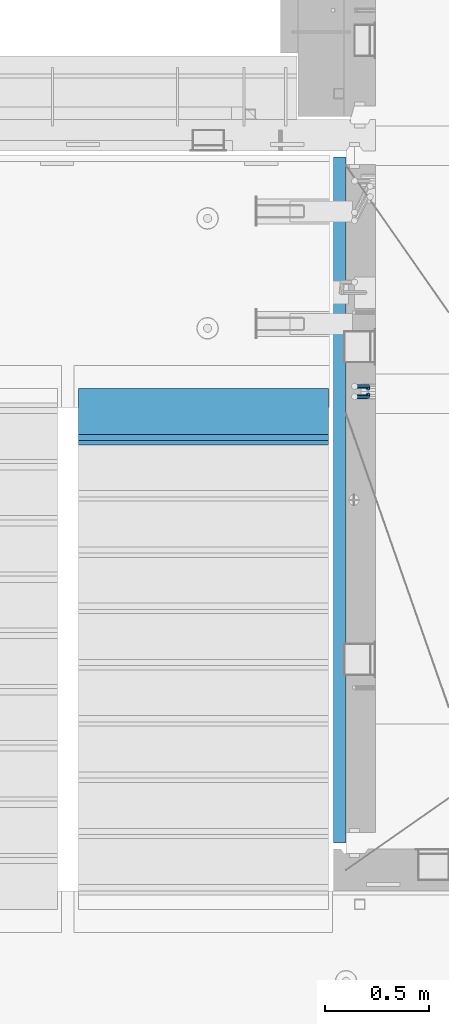
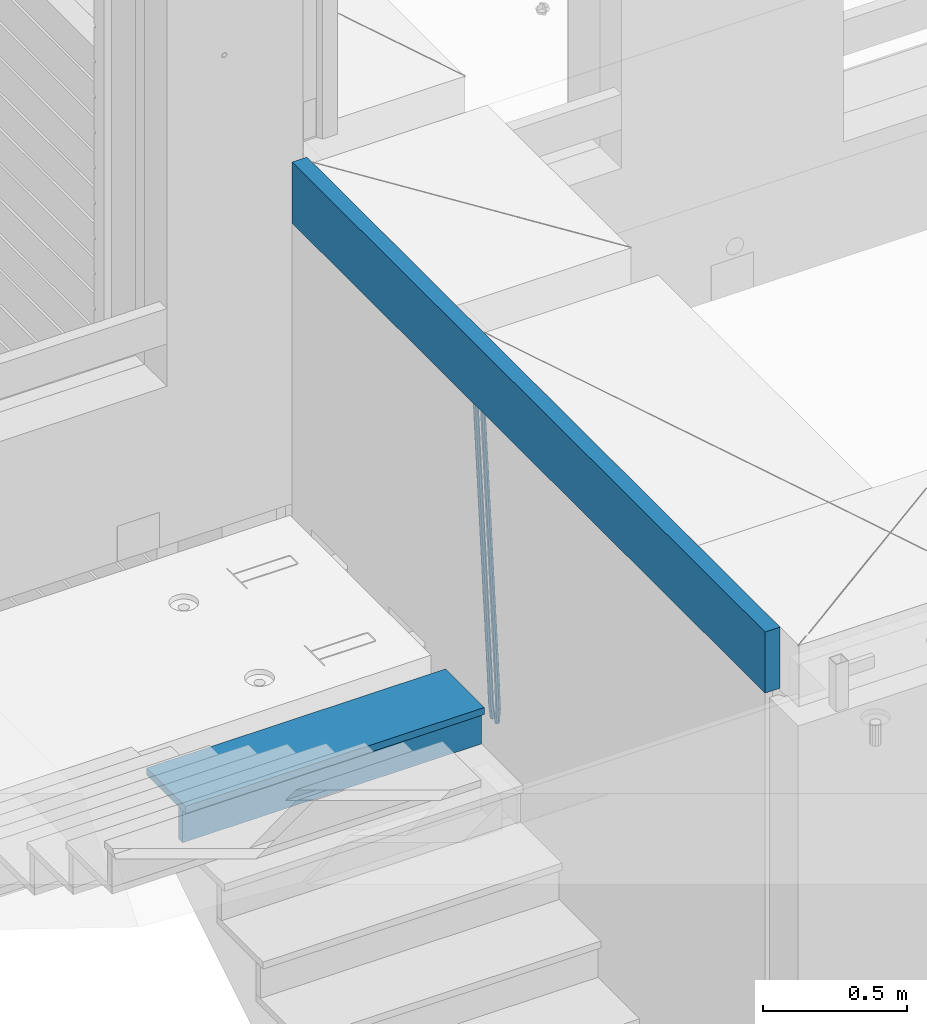
# One storey, part 120 of 350: 5 beams, 2 elements without a shape of their own.
"""IFC2X3 building model written with IfcOpenShell, lengths in millimetres."""

from ifc_helpers import new_model, si_unit, frame, origin_with_axes, place, context, subcontext, project, spatial, faceted_brep, material, type_object, element, aggregate, save


model = new_model("IFC2X3")

# Units and contexts
model_context = context("Model", 3, precision=1e-05, world=origin_with_axes())
body_context = subcontext(model_context, "Body", "Model", "MODEL_VIEW")
ifc_project = project(units=[si_unit("LENGTHUNIT", "METRE", prefix="MILLI"), si_unit("AREAUNIT", "SQUARE_METRE"), si_unit("VOLUMEUNIT", "CUBIC_METRE"), si_unit("MASSUNIT", "GRAM", prefix="KILO"), si_unit("TIMEUNIT", "SECOND"), si_unit("PLANEANGLEUNIT", "RADIAN"), si_unit("SOLIDANGLEUNIT", "STERADIAN"), si_unit("THERMODYNAMICTEMPERATUREUNIT", "DEGREE_CELSIUS"), si_unit("LUMINOUSINTENSITYUNIT", "LUMEN")], contexts=[model_context])

# Site, building, storey
site_placement = place(None, origin_with_axes())
site = spatial("IfcSite", under=ifc_project, at=site_placement, CompositionType="ELEMENT")
building_placement = place(site_placement, origin_with_axes())
building = spatial("IfcBuilding", under=site, at=building_placement, CompositionType="ELEMENT")
storey_placement = place(building_placement, origin_with_axes())
storey = spatial("IfcBuildingStorey", under=building, at=storey_placement, Name="2", CompositionType="ELEMENT", Elevation=0.0)

# Assembly, beams
assembly_1_placement = place(storey_placement, origin_with_axes())
assembly_1 = element("IfcElementAssembly", 1, at=assembly_1_placement, inside=storey, AssemblyPlace="NOTDEFINED", PredefinedType="REINFORCEMENT_UNIT")
ifc_material_1 = material()
beam_type_1 = type_object("IfcBeamType", Name="D20", PredefinedType="NOTDEFINED")
beam_1_placement = place(assembly_1_placement, frame((22375.0000022791, 19290.4700000039, 85985.0), z_axis=(-0.15890508605452, 0.973589036334047, -0.163931577056242), x_axis=(-0.0263727870048703, 0.161796289029781, 0.986471711181718)))
beam_1 = element("IfcBeam", 2, at=beam_1_placement, type_object=beam_type_1, material=ifc_material_1, Name="JM20", ObjectType="D20", context=body_context, shape_type="Brep", body=[
    faceted_brep([(0.0, -10.0, 0.0), (-4.19531716033816e-08, -7.07106781186667, -7.07106781187031), (60.5120847452927, -7.07106784077769, -7.0710678127632), (60.5120847456128, -10.000000028911, -8.96534402272664e-10), (0.0, 0.0, -10.0), (60.5120847479557, -2.89146555587649e-08, -10.0000000008984), (4.196772351861e-08, 7.07106781186303, -7.07106781186667), (60.5120847520593, 7.07106778294838, -7.0710678127632), (0.0, 10.0, 0.0), (60.5120847551734, 9.99999997108898, -8.94715412869118e-10), (4.196772351861e-08, 7.07106781185939, 7.07106781185939), (60.512084755479, 7.07106778295201, 7.07106781097195), (0.0, 0.0, 10.0), (60.512084752816, -2.89110175799578e-08, 9.9999999991071), (-4.19531716033816e-08, -7.07106781187031, 7.07106781185939), (60.5120847487415, -7.07106784077769, 7.07106781096832), (61.1107048256381, -7.07106784106145, -7.07106781277048), (61.616696962592, -10.0000000294385, -9.12905306904577e-10), (61.0120847479702, -2.91511241812259e-08, -10.0000000009038), (61.3786070335627, 7.07106778254092, -7.0710678127723), (61.9955678984406, 9.99999997037958, -9.2018126451876e-10), (62.5015600354091, 7.07106778200614, 7.07106781093921), (62.6001801130624, -2.9907823773101e-08, 9.99999999907436), (62.2336578274699, -7.07106784159623, 7.07106781094103), (61.7013993430301, -7.09359767751084, -7.16550506250837), (62.7066844218498, -10.0415735305724, -0.174261679103211), (61.505464887392, -0.0188181720659486, -10.0788791204338), (62.2336568017054, 7.03845510227256, -7.207768842012), (63.4594101385883, 9.94416717476997, -0.234031689273024), (64.464695217408, 6.99619132171574, 6.75721169413032), (64.6606296730461, -0.0785881837327906, 9.67058575205397), (63.9324377587182, -7.1358614580713, 6.79947547363395), (179.287252569251, -11.5784709304826, -25.9645361348155), (180.292537648071, -14.5264467835441, -18.973292751414), (179.091318113613, -4.50369142503769, -28.877910192741), (179.819510027926, 2.55358184929719, -26.0067999143191), (181.045263364809, 5.45929392180187, -19.033062761582), (182.050548443614, 2.511318068744, -12.0418193781786), (182.246482899252, -4.56346143670453, -9.12844532025679), (181.518290984939, -11.6207347110394, -11.9995555986786), (179.796944029818, -11.5979112078276, -26.0460230258138), (180.785917787493, -14.5452649264626, -19.0521718709458), (179.631039013402, -4.52427706319941, -28.9641980384947), (180.385387646791, 2.53199856077117, -26.0972695639282), (181.618102731314, 5.43744510340548, -19.1246454201662), (182.607076488988, 2.49009138477413, -12.1307942652963), (182.772981505375, -4.58354275985403, -9.21261925261729), (182.018632872001, -11.6398183838246, -12.0795477271802), (180.306575384253, -11.6215474691344, -26.1267734773298), (181.279244090445, -14.5681079330752, -19.1303214631914), (180.170689328603, -4.54931932109321, -29.0497458967745), (180.951186131948, 2.5057611781267, -26.1870011206463), (182.190861352254, 5.41092355571527, -19.2154962132006), (183.16353005846, 2.46436309177807, -12.2190441990567), (183.299416114096, -4.60786505625947, -9.29607177961748), (182.518919310765, -11.662945555483, -12.1588165557403), (300.637581828458, -17.193417372393, -45.2021641841727), (301.610250534635, -20.1399778363302, -38.2057121700307), (300.501695772793, -10.1211892243555, -48.125136603612), (301.282192576138, -3.06610872513556, -45.2623918274874), (302.521867796473, -0.160946347543359, -38.2908869200398), (303.494536502651, -3.10750681148056, -31.2944349058978), (303.630422558286, -10.1797349595217, -28.3714624864531), (302.849925754956, -17.2348154587417, -31.2342072625831), (301.135146648914, -17.2164568742628, -45.2810403078945), (302.103568397841, -20.1628206848691, -38.2839150477537), (301.007079483054, -10.1445907761881, -48.2052522115043), (301.794386909154, -3.08982563961035, -45.3435870847131), (303.035874914756, -0.184747202180006, -38.3723695478091), (304.004296663683, -3.13111101278264, -31.3752442876664), (304.132363829543, -10.2029771108573, -28.4510323840584), (303.345056403443, -17.2577422474315, -31.3126975108532), (301.632689949649, -17.2405558216851, -45.3597353949606), (302.596865217929, -20.1867113775443, -38.3619373656909), (301.512440876206, -10.1690694440185, -48.2851865283189), (302.306558273951, -3.11463305844518, -45.424601167904), (303.549858941391, -0.209639824737678, -38.4536714215171), (304.514034209686, -3.15579538060047, -31.4558733922438), (304.634283283129, -10.2272817582634, -28.5304222588836), (303.840165885384, -17.2817181438368, -31.3910076193022), (1282.62444446853, -64.7506719518351, -200.525713980774), (1283.58861973681, -67.6968275076943, -193.527915951503), (1282.50419539507, -57.6791855741649, -203.451165114133), (1283.29831279283, -50.6247491885915, -200.590579753716), (1284.54161346027, -47.7197559548877, -193.619650007329), (1285.50578872855, -50.6659115107432, -186.621851978058), (1285.62603780199, -57.7373978884098, -183.696400844703), (1284.83192040426, -64.7918342739831, -186.556986205121), (1283.16036625447, -64.7766270183929, -200.610482102403), (1284.18303170854, -67.7256152948248, -193.621935615638), (1282.99823367732, -57.703112193376, -203.529308414698), (1283.79160904189, -50.6486398706256, -200.668605684988), (1285.07574381966, -47.7456242614098, -193.704134774427), (1286.09840927372, -50.6946125378345, -186.715588287659), (1286.26054185088, -57.7681273628514, -183.796761975365), (1285.4671664863, -64.8225996856127, -186.657464705073), (1283.69517474226, -64.7992414390355, -200.702893843656), (1284.77620887742, -67.7506978399178, -193.72443311951), (1283.49124566819, -57.7239592457336, -203.61449796867), (1284.28388054106, -50.6694556112197, -200.753667286384), (1285.60876460234, -47.7681630887928, -193.796237610821), (1286.68979873748, -50.7196194896715, -186.817776886675), (1286.89372781155, -57.7949016829771, -183.906172761662), (1286.10109293868, -64.8494053174909, -186.767003443949), (1305.19726392522, -65.7084590385093, -204.418327587487), (1306.27829806038, -68.6599154393916, -197.43986686334), (1304.99333485115, -58.6331768452073, -207.3299317125), (1305.78596972401, -51.5786732107008, -204.469101030216), (1307.11085378527, -48.6773806882629, -197.511671354648), (1308.19188792045, -51.6288370891452, -190.533210630503), (1308.39581699451, -58.7041192824508, -187.62160650549), (1307.60318212165, -65.758622916961, -190.482437187782), (1305.83218118416, -65.7353065667266, -204.528037531872), (1306.8626665273, -68.6846255078017, -197.540842275655), (1305.64065308902, -58.6605487498273, -207.441784472648), (1306.40027680244, -51.6046492357418, -204.575249657393), (1307.66607505539, -48.7008582650778, -197.607610303868), (1308.69656039854, -51.6501772061529, -190.620415047653), (1308.88808849367, -58.7249350230522, -187.706668106881), (1308.12846478027, -65.7808345371377, -190.573202922138), (1306.46882402551, -65.7602792894941, -204.627733284394), (1307.44862319478, -68.7076100329687, -197.632600773693), (1306.28973061276, -58.6860092309689, -207.543427447275), (1307.01625344875, -51.6288113137889, -204.671709165457), (1308.2228053096, -48.7226963654903, -197.694792061111), (1309.20260447887, -51.6700271089649, -190.699659550409), (1309.38169789161, -58.74429716749, -187.783965387529), (1308.65517505561, -65.80149508467, -190.655683669345), (1405.22131312029, -69.6339088545756, -220.091982741469), (1406.20111228956, -72.5812395980538, -213.096850230768), (1405.04221970754, -62.5596387960541, -223.007676904353), (1405.76874254357, -55.5024408788704, -220.135958622533), (1406.97529440439, -52.5963259305718, -213.159041518189), (1407.95509357366, -55.54365667405, -206.163909007488), (1408.13418698641, -62.6179267325751, -203.248214844601), (1407.40766415041, -69.6751246497552, -206.119933126425)], [[[0, 1, 2, 3]], [[1, 4, 5, 2]], [[4, 6, 7, 5]], [[6, 8, 9, 7]], [[8, 10, 11, 9]], [[10, 12, 13, 11]], [[12, 14, 15, 13]], [[14, 0, 3, 15]], [[14, 12, 10, 8, 6, 4, 1, 0]], [[3, 2, 16, 17]], [[2, 5, 18, 16]], [[5, 7, 19, 18]], [[7, 9, 20, 19]], [[9, 11, 21, 20]], [[11, 13, 22, 21]], [[13, 15, 23, 22]], [[15, 3, 17, 23]], [[17, 16, 24, 25]], [[16, 18, 26, 24]], [[18, 19, 27, 26]], [[19, 20, 28, 27]], [[20, 21, 29, 28]], [[21, 22, 30, 29]], [[22, 23, 31, 30]], [[23, 17, 25, 31]], [[25, 24, 32, 33]], [[24, 26, 34, 32]], [[26, 27, 35, 34]], [[27, 28, 36, 35]], [[28, 29, 37, 36]], [[29, 30, 38, 37]], [[30, 31, 39, 38]], [[31, 25, 33, 39]], [[33, 32, 40, 41]], [[32, 34, 42, 40]], [[34, 35, 43, 42]], [[35, 36, 44, 43]], [[36, 37, 45, 44]], [[37, 38, 46, 45]], [[38, 39, 47, 46]], [[39, 33, 41, 47]], [[41, 40, 48, 49]], [[40, 42, 50, 48]], [[42, 43, 51, 50]], [[43, 44, 52, 51]], [[44, 45, 53, 52]], [[45, 46, 54, 53]], [[46, 47, 55, 54]], [[47, 41, 49, 55]], [[49, 48, 56, 57]], [[48, 50, 58, 56]], [[50, 51, 59, 58]], [[51, 52, 60, 59]], [[52, 53, 61, 60]], [[53, 54, 62, 61]], [[54, 55, 63, 62]], [[55, 49, 57, 63]], [[57, 56, 64, 65]], [[56, 58, 66, 64]], [[58, 59, 67, 66]], [[59, 60, 68, 67]], [[60, 61, 69, 68]], [[61, 62, 70, 69]], [[62, 63, 71, 70]], [[63, 57, 65, 71]], [[65, 64, 72, 73]], [[64, 66, 74, 72]], [[66, 67, 75, 74]], [[67, 68, 76, 75]], [[68, 69, 77, 76]], [[69, 70, 78, 77]], [[70, 71, 79, 78]], [[71, 65, 73, 79]], [[73, 72, 80, 81]], [[72, 74, 82, 80]], [[74, 75, 83, 82]], [[75, 76, 84, 83]], [[76, 77, 85, 84]], [[77, 78, 86, 85]], [[78, 79, 87, 86]], [[79, 73, 81, 87]], [[81, 80, 88, 89]], [[80, 82, 90, 88]], [[82, 83, 91, 90]], [[83, 84, 92, 91]], [[84, 85, 93, 92]], [[85, 86, 94, 93]], [[86, 87, 95, 94]], [[87, 81, 89, 95]], [[89, 88, 96, 97]], [[88, 90, 98, 96]], [[90, 91, 99, 98]], [[91, 92, 100, 99]], [[92, 93, 101, 100]], [[93, 94, 102, 101]], [[94, 95, 103, 102]], [[95, 89, 97, 103]], [[97, 96, 104, 105]], [[96, 98, 106, 104]], [[98, 99, 107, 106]], [[99, 100, 108, 107]], [[100, 101, 109, 108]], [[101, 102, 110, 109]], [[102, 103, 111, 110]], [[103, 97, 105, 111]], [[105, 104, 112, 113]], [[104, 106, 114, 112]], [[106, 107, 115, 114]], [[107, 108, 116, 115]], [[108, 109, 117, 116]], [[109, 110, 118, 117]], [[110, 111, 119, 118]], [[111, 105, 113, 119]], [[113, 112, 120, 121]], [[112, 114, 122, 120]], [[114, 115, 123, 122]], [[115, 116, 124, 123]], [[116, 117, 125, 124]], [[117, 118, 126, 125]], [[118, 119, 127, 126]], [[119, 113, 121, 127]], [[121, 120, 128, 129]], [[120, 122, 130, 128]], [[122, 123, 131, 130]], [[123, 124, 132, 131]], [[124, 125, 133, 132]], [[125, 126, 134, 133]], [[126, 127, 135, 134]], [[127, 121, 129, 135]], [[130, 131, 132, 133, 134, 135, 129, 128]]]),
])
beam_2_placement = place(assembly_1_placement, frame((22375.0000022791, 19260.4700000039, 85985.0), z_axis=(-0.158495816053634, -0.973655762329485, -0.163931488055477), x_axis=(-0.0263727879979646, -0.161796198987477, 0.986471725923465)))
beam_2 = element("IfcBeam", 3, at=beam_2_placement, type_object=beam_type_1, material=ifc_material_1, Name="JM20", ObjectType="D20", context=body_context, shape_type="Brep", body=[
    faceted_brep([(0.0, -10.0, 0.0), (-4.19531716033816e-08, -7.07106781186667, -7.07106781187031), (60.5120052037528, -7.07106781749098, -7.07106782543269), (60.5120052045822, -10.0000000056316, -1.35623849928379e-08), (0.0, 0.0, -10.0), (60.512005203942, -5.62431523576379e-09, -10.0000000135624), (4.196772351861e-08, 7.07106781186303, -7.07106781186667), (60.5120052050625, 7.07106780623872, -7.07106782543269), (0.0, 10.0, 0.0), (60.5120052064449, 9.99999999437205, -1.35623849928379e-08), (4.196772351861e-08, 7.07106781185939, 7.07106781185939), (60.5120052072889, 7.07106780623872, 7.07106779830065), (0.0, 0.0, 10.0), (60.5120052070852, -5.62795321457088e-09, 9.99999998643762), (-4.19531716033816e-08, -7.07106781187031, 7.07106781185939), (60.5120052059501, -7.07106781749098, 7.07106779830065), (61.3783176868601, -7.07106781757102, -7.07106782562914), (61.9952377020818, -10.0000000057662, -1.38970790430903e-08), (61.0120052039565, -5.67160896025598e-09, -10.0000000136788), (61.1108811377926, 7.07106780618051, -7.07106782556366), (61.6170253073215, 9.99999999427382, -1.38097675517201e-08), (62.2339453225432, 7.07106780607864, 7.07106779791502), (62.6002578054613, -5.81712811253965e-09, 9.99999998597195), (62.5013818716106, -7.07106781767652, 7.07106779785681), (62.2331604305218, -7.03851970548931, -7.2077492888784), (63.4588326085068, -9.94427367315438, -0.23401532828575), (61.5053853412101, 0.0187854284049536, -10.0788869429962), (61.7018281175842, 7.09356809489327, -7.16555479231465), (62.7074152454443, 10.041516558791, -0.174343299004249), (63.9330874234438, 7.13576259111869, 6.79939066157385), (64.6608625127556, 0.078457457228069, 9.6705283156989), (64.4644197363668, -6.99632520926025, 6.75719616502465), (179.818932802998, -2.5614449136192, -26.0086288006423), (181.044604980983, -5.46719888128791, -19.034894840057), (179.091157713687, 4.49586022027506, -28.8797664547601), (179.287600490061, 11.5706428867597, -25.9664343040859), (180.293187617921, 14.5185913506575, -18.9752228107754), (181.51885979592, 11.6128373829924, -12.0014888501901), (182.246634885232, 4.55553224909454, -9.13035119606502), (182.050192108843, -2.51925041739014, -12.0436833467465), (180.384803383684, -2.53989940806059, -26.0991062826724), (181.617449868121, -5.44538782921518, -19.126487449299), (179.630864755702, 4.51640954987306, -28.9660606284815), (179.797281007268, 11.5900489573214, -26.0479275136822), (180.786567755189, 14.5373767847341, -19.0541097400928), (182.019214239626, 11.6318883635759, -12.0814909067267), (182.773152867594, 4.5755794056422, -9.21453656090307), (182.606736616028, -2.49806000179888, -12.1326696757169), (180.950594849404, -2.51369963445904, -26.1888475202795), (182.190214025846, -5.41890367426822, -19.2173500092686), (180.170501221772, 4.54141556354443, -29.051616675737), (180.306901410135, 11.613651120846, -26.1286861303379), (181.279894034014, 14.5601873642845, -19.132268955691), (182.519513210456, 11.6549833244717, -12.16077144468), (183.299606838089, 4.59986812646821, -9.29800228921522), (183.163206649726, -2.4723674308334, -12.2209328346216), (301.281596738394, 3.05026059481679, -45.2665532172323), (302.521215914836, 0.145056555003976, -38.2950557062213), (300.501503110776, 10.1053757928166, -48.1293223726971), (300.637903299124, 17.1776113501182, -45.2063918272906), (301.610895923019, 20.1241475935603, -38.2099746526364), (302.850515099461, 17.2189435537439, -31.2384771416328), (303.630608727079, 10.163828355744, -28.375707986168), (303.494208538745, 3.09159279844243, -31.2986385315744), (301.793789297284, 3.07394376027514, -45.3477580501058), (303.035224417355, 0.168823687501572, -38.3765484452742), (301.006883331909, 10.128743964, -48.2094471532764), (301.135465363477, 17.2006180191747, -45.285277089446), (302.104213781728, 20.14695801567, -38.2881870233177), (303.345648901799, 17.2418379429, -31.3169774184789), (304.132554867159, 10.1870377391679, -28.455288315301), (304.003972835591, 3.11516368399316, -31.3794583791459), (302.305958891287, 3.09871749445665, -45.4287821432372), (303.549209831341, 0.193682665365486, -38.4578608624288), (301.512241238641, 10.1531893083702, -48.2893910778876), (301.633005909636, 17.2246841938904, -45.3639817491057), (302.597510597858, 20.1708163533331, -38.3662192661868), (303.840761537926, 17.2657815242455, -31.3952979853784), (304.634479190572, 10.211309710332, -28.5346890507208), (304.513714519577, 3.13981482481177, -31.4600983795099), (1283.29235311947, 50.544232039254, -200.613633821762), (1284.53560405952, 47.6391972101628, -193.642712540946), (1282.49863546679, 57.5987038531639, -203.474242756405), (1282.6194001378, 64.6701987386878, -200.548833427623), (1283.58390482602, 67.6163308981268, -193.551070944704), (1284.82715576609, 64.7112960690356, -186.580149663889), (1285.62087341874, 57.6568242551293, -183.719540729246), (1285.50010874774, 50.5853293696091, -186.644950058035), (1283.86584870378, 50.5719692160856, -200.704356616399), (1285.05399320807, 47.6642691581874, -193.72471790167), (1283.12497041782, 57.628996611762, -203.573324351266), (1283.26535480202, 64.701440406865, -200.651018717188), (1284.20476658808, 67.6463589453451, -193.649286721222), (1285.39291109238, 64.7386588874433, -186.6696480065), (1286.13378937833, 57.6816314917669, -183.800680271634), (1285.99340499415, 50.6091876966675, -186.722985905704), (1284.44060590031, 50.5936921758439, -200.788496023008), (1285.57352274218, 47.68390478734, -193.800772463459), (1283.75268322045, 57.6527210297136, -203.665215993606), (1283.91273047855, 64.7259079835276, -200.745788831606), (1284.82699416149, 67.6698760489453, -193.740375374167), (1285.95991100336, 64.7600886604341, -186.752651814619), (1286.64783368325, 57.7010598065717, -183.875931844028), (1286.48778642512, 50.6278728527504, -186.795359006021), (1306.02894027183, 51.4096237058839, -203.948838607132), (1307.16185711371, 48.4998363173727, -196.961115047583), (1305.34101759194, 58.4686525597535, -206.825558577722), (1305.50106485008, 65.5418395135639, -203.90613141573), (1306.415328533, 68.4858075789816, -196.900717958291), (1307.54824537487, 65.5760201904777, -189.912994398743), (1308.23616805475, 58.5169913366044, -187.036274428152), (1308.07612079663, 51.4438043827904, -189.955701590145), (1306.55429855913, 51.4294796328759, -204.025746447209), (1307.74597489809, 48.5219130607366, -197.046624762064), (1305.83539902292, 58.4873377158401, -206.897931678046), (1306.0103978878, 65.5610897659317, -203.980693299985), (1306.97678319212, 68.507027769072, -196.982909990227), (1308.16845953107, 65.5994611969327, -190.00378830509), (1308.88735906727, 58.5416031139684, -187.131603074253), (1308.71236020241, 51.4678510638769, -190.048841452306), (1307.07832423707, 51.4505295560484, -204.110977857723), (1308.32861102538, 48.5453173445967, -197.141389009383), (1306.32852641959, 58.507146466156, -206.978137563652), (1306.51843896537, 65.5814975934481, -204.063324856921), (1307.5368136808, 68.5295239925508, -197.073997489359), (1308.78710046913, 65.6243117811064, -190.104408641026), (1309.53689828661, 58.5676948709952, -187.237248935096), (1309.34698574082, 51.4933437436994, -190.152061641827), (1405.73383542724, 55.413485988287, -220.157039583137), (1406.98412221558, 52.5082737768425, -213.187450734797), (1404.98403760976, 62.4701028983982, -223.024199289066), (1405.17395015556, 69.544454025694, -220.109386582335), (1406.19232487098, 72.492480424793, -213.12005921478), (1407.44261165931, 69.5872682133449, -206.15047036644), (1408.1924094768, 62.5306513032374, -203.28331066051), (1408.00249693099, 55.4563001759452, -206.198123367241)], [[[0, 1, 2, 3]], [[1, 4, 5, 2]], [[4, 6, 7, 5]], [[6, 8, 9, 7]], [[8, 10, 11, 9]], [[10, 12, 13, 11]], [[12, 14, 15, 13]], [[14, 0, 3, 15]], [[14, 12, 10, 8, 6, 4, 1, 0]], [[3, 2, 16, 17]], [[2, 5, 18, 16]], [[5, 7, 19, 18]], [[7, 9, 20, 19]], [[9, 11, 21, 20]], [[11, 13, 22, 21]], [[13, 15, 23, 22]], [[15, 3, 17, 23]], [[17, 16, 24, 25]], [[16, 18, 26, 24]], [[18, 19, 27, 26]], [[19, 20, 28, 27]], [[20, 21, 29, 28]], [[21, 22, 30, 29]], [[22, 23, 31, 30]], [[23, 17, 25, 31]], [[25, 24, 32, 33]], [[24, 26, 34, 32]], [[26, 27, 35, 34]], [[27, 28, 36, 35]], [[28, 29, 37, 36]], [[29, 30, 38, 37]], [[30, 31, 39, 38]], [[31, 25, 33, 39]], [[33, 32, 40, 41]], [[32, 34, 42, 40]], [[34, 35, 43, 42]], [[35, 36, 44, 43]], [[36, 37, 45, 44]], [[37, 38, 46, 45]], [[38, 39, 47, 46]], [[39, 33, 41, 47]], [[41, 40, 48, 49]], [[40, 42, 50, 48]], [[42, 43, 51, 50]], [[43, 44, 52, 51]], [[44, 45, 53, 52]], [[45, 46, 54, 53]], [[46, 47, 55, 54]], [[47, 41, 49, 55]], [[49, 48, 56, 57]], [[48, 50, 58, 56]], [[50, 51, 59, 58]], [[51, 52, 60, 59]], [[52, 53, 61, 60]], [[53, 54, 62, 61]], [[54, 55, 63, 62]], [[55, 49, 57, 63]], [[57, 56, 64, 65]], [[56, 58, 66, 64]], [[58, 59, 67, 66]], [[59, 60, 68, 67]], [[60, 61, 69, 68]], [[61, 62, 70, 69]], [[62, 63, 71, 70]], [[63, 57, 65, 71]], [[65, 64, 72, 73]], [[64, 66, 74, 72]], [[66, 67, 75, 74]], [[67, 68, 76, 75]], [[68, 69, 77, 76]], [[69, 70, 78, 77]], [[70, 71, 79, 78]], [[71, 65, 73, 79]], [[73, 72, 80, 81]], [[72, 74, 82, 80]], [[74, 75, 83, 82]], [[75, 76, 84, 83]], [[76, 77, 85, 84]], [[77, 78, 86, 85]], [[78, 79, 87, 86]], [[79, 73, 81, 87]], [[81, 80, 88, 89]], [[80, 82, 90, 88]], [[82, 83, 91, 90]], [[83, 84, 92, 91]], [[84, 85, 93, 92]], [[85, 86, 94, 93]], [[86, 87, 95, 94]], [[87, 81, 89, 95]], [[89, 88, 96, 97]], [[88, 90, 98, 96]], [[90, 91, 99, 98]], [[91, 92, 100, 99]], [[92, 93, 101, 100]], [[93, 94, 102, 101]], [[94, 95, 103, 102]], [[95, 89, 97, 103]], [[97, 96, 104, 105]], [[96, 98, 106, 104]], [[98, 99, 107, 106]], [[99, 100, 108, 107]], [[100, 101, 109, 108]], [[101, 102, 110, 109]], [[102, 103, 111, 110]], [[103, 97, 105, 111]], [[105, 104, 112, 113]], [[104, 106, 114, 112]], [[106, 107, 115, 114]], [[107, 108, 116, 115]], [[108, 109, 117, 116]], [[109, 110, 118, 117]], [[110, 111, 119, 118]], [[111, 105, 113, 119]], [[113, 112, 120, 121]], [[112, 114, 122, 120]], [[114, 115, 123, 122]], [[115, 116, 124, 123]], [[116, 117, 125, 124]], [[117, 118, 126, 125]], [[118, 119, 127, 126]], [[119, 113, 121, 127]], [[121, 120, 128, 129]], [[120, 122, 130, 128]], [[122, 123, 131, 130]], [[123, 124, 132, 131]], [[124, 125, 133, 132]], [[125, 126, 134, 133]], [[126, 127, 135, 134]], [[127, 121, 129, 135]], [[130, 131, 132, 133, 134, 135, 129, 128]]]),
])
ifc_material_2 = material(Name="CONCRETE/C25/30")
beam_type_2 = type_object("IfcBeamType", Name="260X60", PredefinedType="NOTDEFINED")
beam_3_placement = place(assembly_1_placement, frame((22240.0000000001, 20400.0, 87600.0), z_axis=(0.0, 0.0, 1.0), x_axis=(0.0, -1.0, 0.0)))
beam_3 = element("IfcBeam", 4, at=beam_3_placement, type_object=beam_type_2, material=ifc_material_2, ObjectType="260X60", context=body_context, shape_type="Brep", body=[
    faceted_brep([(0.0, 30.0, -130.0), (0.0, 30.0, 130.0), (3290.0, 30.0, 130.0), (3290.0, 30.0, -130.0), (0.0, -30.0, 130.0), (3290.0, -30.0, 130.0), (0.0, -30.0, -130.0), (3290.0, -30.0, -130.0)], [[[0, 1, 2, 3]], [[1, 4, 5, 2]], [[4, 6, 7, 5]], [[6, 0, 3, 7]], [[5, 7, 3, 2]], [[6, 4, 1, 0]]]),
])
aggregate(assembly_1, [beam_1, beam_2, beam_3])

assembly_2_placement = place(storey_placement, origin_with_axes())
assembly_2 = element("IfcElementAssembly", 5, at=assembly_2_placement, inside=storey, Name="E9", AssemblyPlace="NOTDEFINED", PredefinedType="NOTDEFINED")
ifc_material_3 = material(Name="Undefined/C32/40")
beam_type_3 = type_object("IfcBeamType", PredefinedType="NOTDEFINED")
beam_4_placement = place(assembly_2_placement, frame((20985.002175553, 19055.001025346, 86161.803607297), z_axis=(0.0, -1.0, 0.0), x_axis=(1.0, 0.0, 0.0)))
beam_4 = element("IfcBeam", 6, at=beam_4_placement, type_object=beam_type_3, material=ifc_material_3, Name="E9", context=body_context, shape_type="Brep", body=[
    faceted_brep([(0.0, 68.5, -15.0), (0.0, 68.5, 15.0), (1200.0, 68.5, 15.0), (1200.0, 68.5, -15.0), (0.0, -68.5, 15.0), (1200.0, -68.5, 15.0), (0.0, -68.5, -15.0), (1200.0, -68.5, -15.0)], [[[0, 1, 2, 3]], [[1, 4, 5, 2]], [[4, 6, 7, 5]], [[6, 0, 3, 7]], [[5, 7, 3, 2]], [[6, 4, 1, 0]]]),
])
beam_type_4 = type_object("IfcBeamType", PredefinedType="NOTDEFINED")
beam_5_placement = place(assembly_2_placement, frame((20985.002175553, 19155.001025346, 86245.003607297), z_axis=(0.0, -1.0, 0.0), x_axis=(1.0, 0.0, 0.0)))
beam_5 = element("IfcBeam", 7, at=beam_5_placement, type_object=beam_type_4, material=ifc_material_3, Name="E9", context=body_context, shape_type="Brep", body=[
    faceted_brep([(0.0, 15.0, -135.0), (0.0, 15.0, 135.0), (1200.0, 15.0, 135.0), (1200.0, 15.0, -135.0), (0.0, -15.0, 135.0), (1200.0, -15.0, 135.0), (0.0, -15.0, -135.0), (1200.0, -15.0, -135.0)], [[[0, 1, 2, 3]], [[1, 4, 5, 2]], [[4, 6, 7, 5]], [[6, 0, 3, 7]], [[5, 7, 3, 2]], [[6, 4, 1, 0]]]),
])
aggregate(assembly_2, [beam_5, beam_4])

save(model, "model.ifc")
